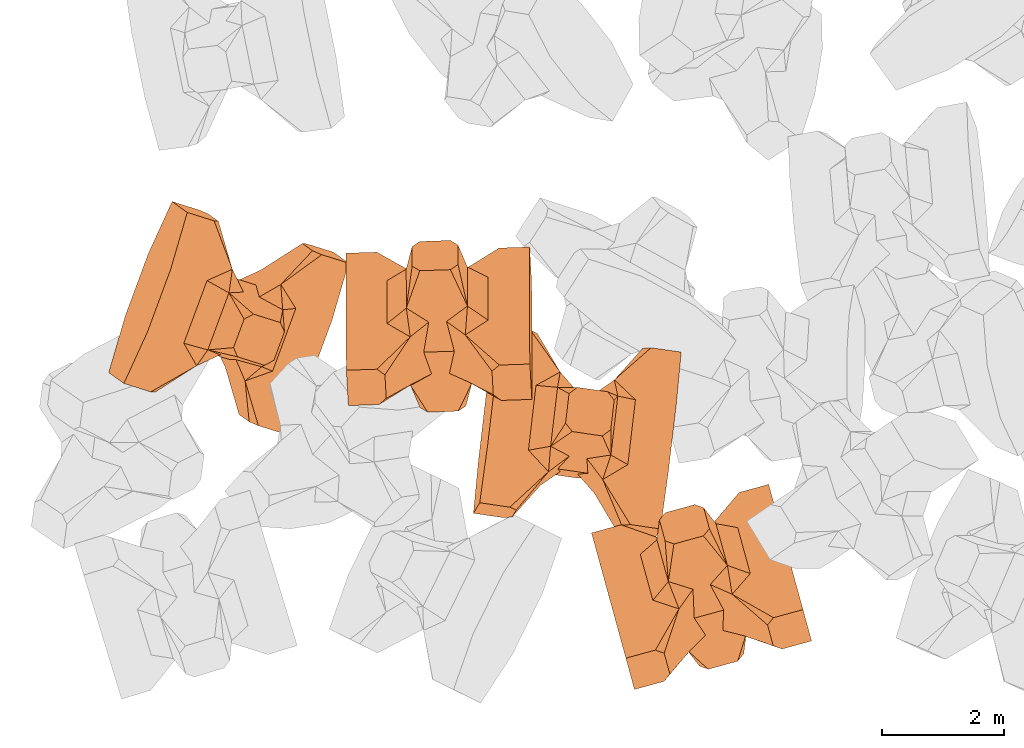
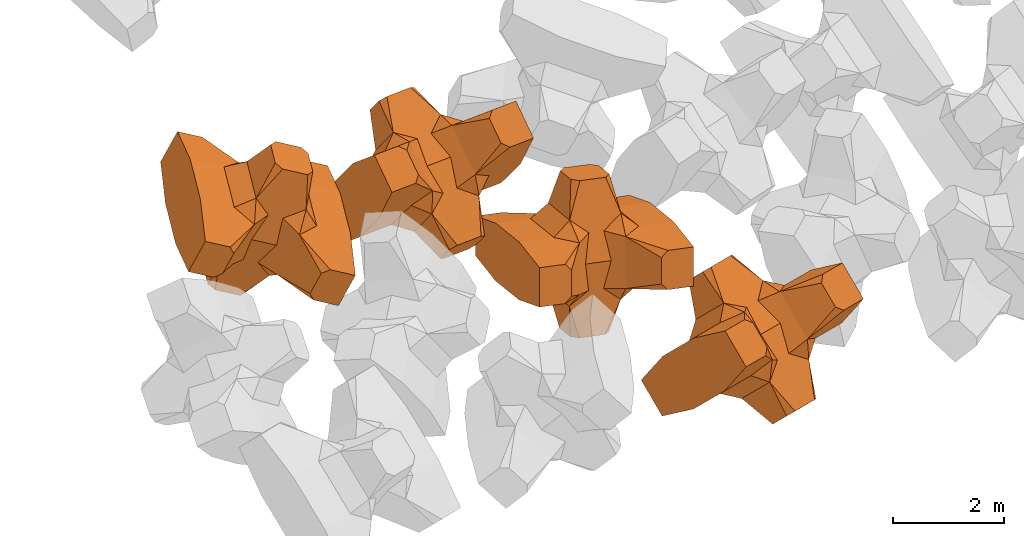
# One storey, part 2 of 17: 4 civil elements.
"""IFC4 building model written with IfcOpenShell, lengths in metres."""

from ifc_helpers import new_model, entity, si_unit, converted_unit, frame, origin_with_axes, origin_2d_with_axis, place, context, subcontext, project, spatial, polygons, element, save


model = new_model("IFC4")

# Units and contexts
model_context = context("Model", 3, precision=1e-05, world=origin_with_axes())
plan_context = context("Plan", 2, precision=1e-05, world=origin_2d_with_axis())
body_context = subcontext(model_context, "Body", "Model", "MODEL_VIEW")
ifc_project = project(units=[si_unit("VOLUMEUNIT", "CUBIC_METRE"), si_unit("LENGTHUNIT", "METRE"), converted_unit("PLANEANGLEUNIT", "degree", entity("IfcReal", 0.0174532925199433), si_unit("PLANEANGLEUNIT", "RADIAN"), dimensions=[0, 0, 0, 0, 0, 0, 0]), si_unit("AREAUNIT", "SQUARE_METRE")], contexts=[model_context, plan_context])

# Site, building, storey
site_placement = place(None, origin_with_axes())
site = spatial("IfcSite", under=ifc_project, at=site_placement)
building_placement = place(site_placement, origin_with_axes())
building = spatial("IfcBuilding", under=site, at=building_placement, Name="Building")
storey_placement = place(building_placement, origin_with_axes())
storey = spatial("IfcBuildingStorey", under=building, at=storey_placement, Name="Storey")

# Civil elements
civil_element_1_placement = place(storey_placement, frame((10.1557922363281, -20.4937763214111, 2.37215161323547), z_axis=(0.186987502851057, -0.681988531796913, -0.707055384163799), x_axis=(-0.18698757723591, 0.681881898647202, -0.707158201717785)))
element("IfcCivilElement", 1, at=civil_element_1_placement, inside=storey, ObjectType="IfcCivilElementType", context=body_context, shape_type="Tessellation", body=[
    polygons([(0.500000059604645, 0.499999970197678, 0.821428656578064), (0.374999791383743, 0.249999895691872, 1.5), (0.549999952316284, 0.145680591464043, 0.550000071525574), (0.374999791383743, -0.249999970197678, 1.5), (0.651315748691559, -0.249999970197678, 1.45970545872842e-07), (0.651315748691559, 0.249999895691872, 1.45970545872842e-07), (0.549999952316284, -0.145680665969849, 0.550000071525574), (0.500000059604645, -0.499999970197678, 0.821428656578064), (-0.249999970197678, 0.374999731779099, 1.5), (0.249999940395355, 0.374999731779099, 1.5), (-0.5, 0.499999970197678, 0.821428656578064), (-0.549999952316284, 0.824999809265137, 0.550000071525574), (0.549999952316284, 0.824999809265137, 0.550000071525574), (-0.549999952316284, 1.49999976158142, 0.550000071525574), (0.549999952316284, 1.49999976158142, 0.550000071525574), (-0.249999970197678, -0.374999940395355, 1.5), (0.249999940395355, -0.374999940395355, 1.5), (-0.374999940395355, -0.249999970197678, 1.5), (-0.374999940395355, 0.249999895691872, 1.5), (1.49999988079071, 0.874999701976776, -0.249999806284904), (1.49999988079071, 0.874999701976776, 0.25000011920929), (0.845557451248169, 0.449999809265137, -0.495555102825165), (0.845557451248169, 0.449999809265137, 0.495555102825165), (1.49999988079071, 1.49999976158142, -0.374999791383743), (1.49999988079071, 1.49999976158142, 0.374999940395355), (1.49999988079071, 0.999999821186066, -0.374999791383743), (1.49999988079071, 0.999999821186066, 0.374999940395355), (-1.49999988079071, 1.49999976158142, -0.374999791383743), (-1.49999988079071, 1.49999976158142, 0.374999940395355), (-0.549999952316284, 1.49999976158142, -0.54999977350235), (0.549999952316284, 1.49999976158142, -0.54999977350235), (0.549999952316284, 0.145680591464043, -0.54999977350235), (-0.5, -0.499999970197678, 0.821428656578064), (-0.549999952316284, -0.145680665969849, 0.550000071525574), (-0.651315748691559, 0.249999895691872, 1.45970545872842e-07), (-0.651315748691559, -0.249999970197678, 1.45970545872842e-07), (-0.549999952316284, 0.145680591464043, 0.550000071525574), (-1.49999988079071, 0.874999701976776, 0.25000011920929), (-1.49999988079071, 0.874999701976776, -0.249999806284904), (-0.845557332038879, 0.449999809265137, 0.495555102825165), (-0.845557332038879, 0.449999809265137, -0.495555102825165), (-1.49999988079071, 0.999999821186066, 0.374999940395355), (-1.49999988079071, 0.999999821186066, -0.374999791383743), (-0.549999952316284, 0.145680591464043, -0.54999977350235), (0.549999952316284, -0.824999988079071, 0.550000071525574), (-0.549999952316284, -0.824999988079071, 0.550000071525574), (0.549999952316284, -1.49999976158142, 0.550000071525574), (-0.549999952316284, -1.49999976158142, 0.550000071525574), (1.49999988079071, -0.874999940395355, 0.25000011920929), (1.49999988079071, -0.874999940395355, -0.249999806284904), (0.845557451248169, -0.450000047683716, 0.495555102825165), (0.845557451248169, -0.450000047683716, -0.495555102825165), (1.49999988079071, -1.49999976158142, 0.374999940395355), (1.49999988079071, -1.49999976158142, -0.374999791383743), (1.49999988079071, -0.999999940395355, 0.374999940395355), (1.49999988079071, -0.999999940395355, -0.374999791383743), (0.549999952316284, -1.49999976158142, -0.54999977350235), (-0.549999952316284, -1.49999976158142, -0.54999977350235), (-1.49999988079071, -1.49999976158142, -0.374999791383743), (-1.49999988079071, -1.49999976158142, 0.374999940395355), (0.549999952316284, -0.145680665969849, -0.54999977350235), (-1.49999988079071, -0.874999940395355, -0.249999806284904), (-1.49999988079071, -0.874999940395355, 0.25000011920929), (-0.845557332038879, -0.450000047683716, -0.495555102825165), (-0.845557332038879, -0.450000047683716, 0.495555102825165), (-1.49999988079071, -0.999999940395355, -0.374999791383743), (-1.49999988079071, -0.999999940395355, 0.374999940395355), (-0.549999952316284, -0.145680665969849, -0.54999977350235), (0.500000059604645, -0.499999970197678, -0.821428418159485), (0.374999791383743, -0.249999970197678, -1.49999976158142), (0.374999791383743, 0.249999895691872, -1.49999976158142), (0.500000059604645, 0.499999970197678, -0.821428418159485), (0.249999940395355, 0.374999731779099, -1.49999976158142), (-0.249999970197678, 0.374999731779099, -1.49999976158142), (-0.5, 0.499999970197678, -0.821428418159485), (0.549999952316284, 0.824999809265137, -0.54999977350235), (-0.549999952316284, 0.824999809265137, -0.54999977350235), (0.249999940395355, -0.374999940395355, -1.49999976158142), (-0.249999970197678, -0.374999940395355, -1.49999976158142), (-0.374999940395355, -0.249999970197678, -1.49999976158142), (-0.374999940395355, 0.249999895691872, -1.49999976158142), (-0.5, -0.499999970197678, -0.821428418159485), (-0.549999952316284, -0.824999988079071, -0.54999977350235), (0.549999952316284, -0.824999988079071, -0.54999977350235)], [[[1, 2, 3]], [[3, 2, 4]], [[5, 6, 7]], [[7, 6, 3]], [[7, 3, 8]], [[8, 3, 4]], [[9, 10, 11]], [[11, 10, 1]], [[12, 13, 14]], [[14, 13, 15]], [[16, 17, 18]], [[18, 17, 4]], [[18, 4, 19]], [[19, 4, 2]], [[19, 2, 9]], [[9, 2, 10]], [[20, 21, 22]], [[22, 21, 23]], [[24, 25, 26]], [[26, 25, 27]], [[26, 27, 20]], [[20, 27, 21]], [[23, 27, 13]], [[13, 27, 25]], [[13, 25, 15]], [[28, 29, 30]], [[30, 29, 14]], [[30, 14, 31]], [[31, 14, 15]], [[31, 15, 24]], [[24, 15, 25]], [[21, 27, 23]], [[2, 1, 10]], [[13, 12, 1]], [[1, 12, 11]], [[13, 1, 23]], [[32, 22, 6]], [[6, 22, 23]], [[6, 23, 3]], [[3, 23, 1]], [[33, 18, 34]], [[34, 18, 19]], [[35, 36, 37]], [[37, 36, 34]], [[37, 34, 11]], [[11, 34, 19]], [[38, 39, 40]], [[40, 39, 41]], [[29, 28, 42]], [[42, 28, 43]], [[42, 43, 38]], [[38, 43, 39]], [[14, 29, 12]], [[12, 29, 42]], [[12, 42, 40]], [[40, 42, 38]], [[9, 11, 19]], [[40, 11, 12]], [[37, 40, 35]], [[35, 40, 41]], [[35, 41, 44]], [[11, 40, 37]], [[17, 16, 8]], [[8, 16, 33]], [[45, 46, 47]], [[47, 46, 48]], [[49, 50, 51]], [[51, 50, 52]], [[53, 54, 55]], [[55, 54, 56]], [[55, 56, 49]], [[49, 56, 50]], [[47, 53, 45]], [[45, 53, 55]], [[45, 55, 51]], [[54, 53, 57]], [[57, 53, 47]], [[57, 47, 58]], [[58, 47, 48]], [[58, 48, 59]], [[59, 48, 60]], [[51, 55, 49]], [[17, 8, 4]], [[46, 45, 33]], [[33, 45, 8]], [[51, 8, 45]], [[7, 51, 5]], [[5, 51, 52]], [[5, 52, 61]], [[8, 51, 7]], [[62, 63, 64]], [[64, 63, 65]], [[59, 60, 66]], [[66, 60, 67]], [[66, 67, 62]], [[62, 67, 63]], [[65, 67, 46]], [[46, 67, 60]], [[46, 60, 48]], [[63, 67, 65]], [[18, 33, 16]], [[46, 33, 65]], [[68, 64, 36]], [[36, 64, 65]], [[36, 65, 34]], [[34, 65, 33]], [[69, 70, 61]], [[61, 70, 71]], [[6, 5, 32]], [[32, 5, 61]], [[32, 61, 72]], [[72, 61, 71]], [[73, 74, 72]], [[72, 74, 75]], [[76, 77, 31]], [[31, 77, 30]], [[78, 79, 70]], [[70, 79, 80]], [[70, 80, 71]], [[71, 80, 81]], [[71, 81, 73]], [[73, 81, 74]], [[31, 24, 76]], [[76, 24, 26]], [[76, 26, 22]], [[22, 26, 20]], [[73, 72, 71]], [[77, 76, 75]], [[75, 76, 72]], [[22, 72, 76]], [[72, 22, 32]], [[75, 81, 44]], [[44, 81, 80]], [[36, 35, 68]], [[68, 35, 44]], [[68, 44, 82]], [[82, 44, 80]], [[41, 43, 77]], [[77, 43, 28]], [[77, 28, 30]], [[39, 43, 41]], [[81, 75, 74]], [[77, 75, 41]], [[44, 41, 75]], [[79, 78, 82]], [[82, 78, 69]], [[83, 84, 58]], [[58, 84, 57]], [[52, 56, 84]], [[84, 56, 54]], [[84, 54, 57]], [[50, 56, 52]], [[70, 69, 78]], [[84, 83, 69]], [[69, 83, 82]], [[84, 69, 52]], [[61, 52, 69]], [[58, 59, 83]], [[83, 59, 66]], [[83, 66, 64]], [[64, 66, 62]], [[79, 82, 80]], [[64, 82, 83]], [[82, 64, 68]]], closed=True),
])
civil_element_2_placement = place(storey_placement, frame((8.1265926361084, -17.9750919342041, 3.49321746826172), z_axis=(-0.136906563876709, -0.229293614024707, -0.963680980062884), x_axis=(0.11298064851695, 0.962878581808255, -0.245153441247749)))
element("IfcCivilElement", 2, at=civil_element_2_placement, inside=storey, ObjectType="IfcCivilElementType", context=body_context, shape_type="Tessellation", body=[
    polygons([(0.500000178813934, 0.500000059604645, 0.821428835391998), (0.374999850988388, 0.249999940395355, 1.50000035762787), (0.550000071525574, 0.145680621266365, 0.550000190734863), (0.374999850988388, -0.250000029802322, 1.50000035762787), (0.651315867900848, -0.250000029802322, 1.45970574294552e-07), (0.651315867900848, 0.249999940395355, 1.45970574294552e-07), (0.550000071525574, -0.145680695772171, 0.550000190734863), (0.500000178813934, -0.500000059604645, 0.821428835391998), (-0.250000029802322, 0.374999791383743, 1.50000035762787), (0.249999985098839, 0.374999791383743, 1.50000035762787), (-0.500000059604645, 0.500000059604645, 0.821428835391998), (-0.550000071525574, 0.824999988079071, 0.550000190734863), (0.550000071525574, 0.824999988079071, 0.550000190734863), (-0.550000071525574, 1.5, 0.550000190734863), (0.550000071525574, 1.5, 0.550000190734863), (-0.250000029802322, -0.375, 1.50000035762787), (0.249999985098839, -0.375, 1.50000035762787), (-0.375, -0.250000029802322, 1.50000035762787), (-0.375, 0.249999940395355, 1.50000035762787), (1.50000023841858, 0.87499988079071, -0.249999865889549), (1.50000023841858, 0.87499988079071, 0.250000149011612), (0.845557630062103, 0.449999898672104, -0.495555222034454), (0.845557630062103, 0.449999898672104, 0.495555222034454), (1.50000023841858, 1.5, -0.374999850988388), (1.50000023841858, 1.5, 0.375), (1.50000023841858, 1.0, -0.374999850988388), (1.50000023841858, 1.0, 0.375), (-1.50000023841858, 1.5, -0.374999850988388), (-1.50000023841858, 1.5, 0.375), (-0.550000071525574, 1.5, -0.549999892711639), (0.550000071525574, 1.5, -0.549999892711639), (0.550000071525574, 0.145680621266365, -0.549999892711639), (-0.500000059604645, -0.500000059604645, 0.821428835391998), (-0.550000071525574, -0.145680695772171, 0.550000190734863), (-0.651315867900848, 0.249999940395355, 1.45970574294552e-07), (-0.651315867900848, -0.250000029802322, 1.45970574294552e-07), (-0.550000071525574, 0.145680621266365, 0.550000190734863), (-1.50000023841858, 0.87499988079071, 0.250000149011612), (-1.50000023841858, 0.87499988079071, -0.249999865889549), (-0.845557451248169, 0.449999898672104, 0.495555222034454), (-0.845557451248169, 0.449999898672104, -0.495555222034454), (-1.50000023841858, 1.0, 0.375), (-1.50000023841858, 1.0, -0.374999850988388), (-0.550000071525574, 0.145680621266365, -0.549999892711639), (0.550000071525574, -0.825000107288361, 0.550000190734863), (-0.550000071525574, -0.825000107288361, 0.550000190734863), (0.550000071525574, -1.5, 0.550000190734863), (-0.550000071525574, -1.5, 0.550000190734863), (1.50000023841858, -0.875000059604645, 0.250000149011612), (1.50000023841858, -0.875000059604645, -0.249999865889549), (0.845557630062103, -0.450000137090683, 0.495555222034454), (0.845557630062103, -0.450000137090683, -0.495555222034454), (1.50000023841858, -1.5, 0.375), (1.50000023841858, -1.5, -0.374999850988388), (1.50000023841858, -1.00000011920929, 0.375), (1.50000023841858, -1.00000011920929, -0.374999850988388), (0.550000071525574, -1.5, -0.549999892711639), (-0.550000071525574, -1.5, -0.549999892711639), (-1.50000023841858, -1.5, -0.374999850988388), (-1.50000023841858, -1.5, 0.375), (0.550000071525574, -0.145680695772171, -0.549999892711639), (-1.50000023841858, -0.875000059604645, -0.249999865889549), (-1.50000023841858, -0.875000059604645, 0.250000149011612), (-0.845557451248169, -0.450000137090683, -0.495555222034454), (-0.845557451248169, -0.450000137090683, 0.495555222034454), (-1.50000023841858, -1.00000011920929, -0.374999850988388), (-1.50000023841858, -1.00000011920929, 0.375), (-0.550000071525574, -0.145680695772171, -0.549999892711639), (0.500000178813934, -0.500000059604645, -0.821428596973419), (0.374999850988388, -0.250000029802322, -1.5), (0.374999850988388, 0.249999940395355, -1.5), (0.500000178813934, 0.500000059604645, -0.821428596973419), (0.249999985098839, 0.374999791383743, -1.5), (-0.250000029802322, 0.374999791383743, -1.5), (-0.500000059604645, 0.500000059604645, -0.821428596973419), (0.550000071525574, 0.824999988079071, -0.549999892711639), (-0.550000071525574, 0.824999988079071, -0.549999892711639), (0.249999985098839, -0.375, -1.5), (-0.250000029802322, -0.375, -1.5), (-0.375, -0.250000029802322, -1.5), (-0.375, 0.249999940395355, -1.5), (-0.500000059604645, -0.500000059604645, -0.821428596973419), (-0.550000071525574, -0.825000107288361, -0.549999892711639), (0.550000071525574, -0.825000107288361, -0.549999892711639)], [[[1, 2, 3]], [[3, 2, 4]], [[5, 6, 7]], [[7, 6, 3]], [[7, 3, 8]], [[8, 3, 4]], [[9, 10, 11]], [[11, 10, 1]], [[12, 13, 14]], [[14, 13, 15]], [[16, 17, 18]], [[18, 17, 4]], [[18, 4, 19]], [[19, 4, 2]], [[19, 2, 9]], [[9, 2, 10]], [[20, 21, 22]], [[22, 21, 23]], [[24, 25, 26]], [[26, 25, 27]], [[26, 27, 20]], [[20, 27, 21]], [[23, 27, 13]], [[13, 27, 25]], [[13, 25, 15]], [[28, 29, 30]], [[30, 29, 14]], [[30, 14, 31]], [[31, 14, 15]], [[31, 15, 24]], [[24, 15, 25]], [[21, 27, 23]], [[2, 1, 10]], [[13, 12, 1]], [[1, 12, 11]], [[13, 1, 23]], [[32, 22, 6]], [[6, 22, 23]], [[6, 23, 3]], [[3, 23, 1]], [[33, 18, 34]], [[34, 18, 19]], [[35, 36, 37]], [[37, 36, 34]], [[37, 34, 11]], [[11, 34, 19]], [[38, 39, 40]], [[40, 39, 41]], [[29, 28, 42]], [[42, 28, 43]], [[42, 43, 38]], [[38, 43, 39]], [[14, 29, 12]], [[12, 29, 42]], [[12, 42, 40]], [[40, 42, 38]], [[9, 11, 19]], [[40, 11, 12]], [[37, 40, 35]], [[35, 40, 41]], [[35, 41, 44]], [[11, 40, 37]], [[17, 16, 8]], [[8, 16, 33]], [[45, 46, 47]], [[47, 46, 48]], [[49, 50, 51]], [[51, 50, 52]], [[53, 54, 55]], [[55, 54, 56]], [[55, 56, 49]], [[49, 56, 50]], [[47, 53, 45]], [[45, 53, 55]], [[45, 55, 51]], [[54, 53, 57]], [[57, 53, 47]], [[57, 47, 58]], [[58, 47, 48]], [[58, 48, 59]], [[59, 48, 60]], [[51, 55, 49]], [[17, 8, 4]], [[46, 45, 33]], [[33, 45, 8]], [[51, 8, 45]], [[7, 51, 5]], [[5, 51, 52]], [[5, 52, 61]], [[8, 51, 7]], [[62, 63, 64]], [[64, 63, 65]], [[59, 60, 66]], [[66, 60, 67]], [[66, 67, 62]], [[62, 67, 63]], [[65, 67, 46]], [[46, 67, 60]], [[46, 60, 48]], [[63, 67, 65]], [[18, 33, 16]], [[46, 33, 65]], [[68, 64, 36]], [[36, 64, 65]], [[36, 65, 34]], [[34, 65, 33]], [[69, 70, 61]], [[61, 70, 71]], [[6, 5, 32]], [[32, 5, 61]], [[32, 61, 72]], [[72, 61, 71]], [[73, 74, 72]], [[72, 74, 75]], [[76, 77, 31]], [[31, 77, 30]], [[78, 79, 70]], [[70, 79, 80]], [[70, 80, 71]], [[71, 80, 81]], [[71, 81, 73]], [[73, 81, 74]], [[31, 24, 76]], [[76, 24, 26]], [[76, 26, 22]], [[22, 26, 20]], [[73, 72, 71]], [[77, 76, 75]], [[75, 76, 72]], [[22, 72, 76]], [[72, 22, 32]], [[75, 81, 44]], [[44, 81, 80]], [[36, 35, 68]], [[68, 35, 44]], [[68, 44, 82]], [[82, 44, 80]], [[41, 43, 77]], [[77, 43, 28]], [[77, 28, 30]], [[39, 43, 41]], [[81, 75, 74]], [[77, 75, 41]], [[44, 41, 75]], [[79, 78, 82]], [[82, 78, 69]], [[83, 84, 58]], [[58, 84, 57]], [[52, 56, 84]], [[84, 56, 54]], [[84, 54, 57]], [[50, 56, 52]], [[70, 69, 78]], [[84, 83, 69]], [[69, 83, 82]], [[84, 69, 52]], [[61, 52, 69]], [[58, 59, 83]], [[83, 59, 66]], [[83, 66, 64]], [[64, 66, 62]], [[79, 82, 80]], [[64, 82, 83]], [[82, 64, 68]]], closed=True),
])
civil_element_3_placement = place(storey_placement, frame((5.86764192581177, -16.2369613647461, 4.94633722305298), z_axis=(-0.0428975516343517, 0.769931841735194, 0.636682620420904), x_axis=(0.00109299982129817, -0.637232659483879, 0.770670709861542)))
element("IfcCivilElement", 3, at=civil_element_3_placement, inside=storey, ObjectType="IfcCivilElementType", context=body_context, shape_type="Tessellation", body=[
    polygons([(0.50000011920929, 0.500001847743988, 0.821428716182709), (0.374999821186066, 0.250000834465027, 1.50000023841858), (0.550000011920929, 0.145681157708168, 0.550000131130219), (0.374999821186066, -0.250000923871994, 1.50000023841858), (0.651315808296204, -0.250000923871994, 1.45970560083697e-07), (0.651315808296204, 0.250000834465027, 1.45970560083697e-07), (0.550000011920929, -0.145681217312813, 0.550000131130219), (0.50000011920929, -0.500001847743988, 0.821428716182709), (-0.25, 0.375001132488251, 1.50000023841858), (0.249999970197678, 0.375001132488251, 1.50000023841858), (-0.500000059604645, 0.500001847743988, 0.821428716182709), (-0.550000011920929, 0.82500296831131, 0.550000131130219), (0.550000011920929, 0.82500296831131, 0.550000131130219), (-0.550000011920929, 1.50000548362732, 0.550000131130219), (0.550000011920929, 1.50000548362732, 0.550000131130219), (-0.25, -0.37500137090683, 1.50000023841858), (0.249999970197678, -0.37500137090683, 1.50000023841858), (-0.374999970197678, -0.250000923871994, 1.50000023841858), (-0.374999970197678, 0.250000834465027, 1.50000023841858), (1.5, 0.875003039836884, -0.249999836087227), (1.5, 0.875003039836884, 0.25000011920929), (0.845557510852814, 0.450001537799835, -0.49555516242981), (0.845557510852814, 0.450001537799835, 0.49555516242981), (1.5, 1.50000548362732, -0.374999821186066), (1.5, 1.50000548362732, 0.374999970197678), (1.5, 1.00000357627869, -0.374999821186066), (1.5, 1.00000357627869, 0.374999970197678), (-1.5, 1.50000548362732, -0.374999821186066), (-1.5, 1.50000548362732, 0.374999970197678), (-0.550000011920929, 1.50000548362732, -0.549999833106995), (0.550000011920929, 1.50000548362732, -0.549999833106995), (0.550000011920929, 0.145681157708168, -0.549999833106995), (-0.500000059604645, -0.500001847743988, 0.821428716182709), (-0.550000011920929, -0.145681217312813, 0.550000131130219), (-0.651315808296204, 0.250000834465027, 1.45970560083697e-07), (-0.651315808296204, -0.250000923871994, 1.45970560083697e-07), (-0.550000011920929, 0.145681157708168, 0.550000131130219), (-1.5, 0.875003039836884, 0.25000011920929), (-1.5, 0.875003039836884, -0.249999836087227), (-0.845557391643524, 0.450001537799835, 0.49555516242981), (-0.845557391643524, 0.450001537799835, -0.49555516242981), (-1.5, 1.00000357627869, 0.374999970197678), (-1.5, 1.00000357627869, -0.374999821186066), (-0.550000011920929, 0.145681157708168, -0.549999833106995), (0.550000011920929, -0.825003087520599, 0.550000131130219), (-0.550000011920929, -0.825003087520599, 0.550000131130219), (0.550000011920929, -1.50000548362732, 0.550000131130219), (-0.550000011920929, -1.50000548362732, 0.550000131130219), (1.5, -0.875003218650818, 0.25000011920929), (1.5, -0.875003218650818, -0.249999836087227), (0.845557510852814, -0.450001746416092, 0.49555516242981), (0.845557510852814, -0.450001746416092, -0.49555516242981), (1.5, -1.50000548362732, 0.374999970197678), (1.5, -1.50000548362732, -0.374999821186066), (1.5, -1.00000369548798, 0.374999970197678), (1.5, -1.00000369548798, -0.374999821186066), (0.550000011920929, -1.50000548362732, -0.549999833106995), (-0.550000011920929, -1.50000548362732, -0.549999833106995), (-1.5, -1.50000548362732, -0.374999821186066), (-1.5, -1.50000548362732, 0.374999970197678), (0.550000011920929, -0.145681217312813, -0.549999833106995), (-1.5, -0.875003218650818, -0.249999836087227), (-1.5, -0.875003218650818, 0.25000011920929), (-0.845557391643524, -0.450001746416092, -0.49555516242981), (-0.845557391643524, -0.450001746416092, 0.49555516242981), (-1.5, -1.00000369548798, -0.374999821186066), (-1.5, -1.00000369548798, 0.374999970197678), (-0.550000011920929, -0.145681217312813, -0.549999833106995), (0.50000011920929, -0.500001847743988, -0.821428537368774), (0.374999821186066, -0.250000923871994, -1.49999988079071), (0.374999821186066, 0.250000834465027, -1.49999988079071), (0.50000011920929, 0.500001847743988, -0.821428537368774), (0.249999970197678, 0.375001132488251, -1.49999988079071), (-0.25, 0.375001132488251, -1.49999988079071), (-0.500000059604645, 0.500001847743988, -0.821428537368774), (0.550000011920929, 0.82500296831131, -0.549999833106995), (-0.550000011920929, 0.82500296831131, -0.549999833106995), (0.249999970197678, -0.37500137090683, -1.49999988079071), (-0.25, -0.37500137090683, -1.49999988079071), (-0.374999970197678, -0.250000923871994, -1.49999988079071), (-0.374999970197678, 0.250000834465027, -1.49999988079071), (-0.500000059604645, -0.500001847743988, -0.821428537368774), (-0.550000011920929, -0.825003087520599, -0.549999833106995), (0.550000011920929, -0.825003087520599, -0.549999833106995)], [[[1, 2, 3]], [[3, 2, 4]], [[5, 6, 7]], [[7, 6, 3]], [[7, 3, 8]], [[8, 3, 4]], [[9, 10, 11]], [[11, 10, 1]], [[12, 13, 14]], [[14, 13, 15]], [[16, 17, 18]], [[18, 17, 4]], [[18, 4, 19]], [[19, 4, 2]], [[19, 2, 9]], [[9, 2, 10]], [[20, 21, 22]], [[22, 21, 23]], [[24, 25, 26]], [[26, 25, 27]], [[26, 27, 20]], [[20, 27, 21]], [[23, 27, 13]], [[13, 27, 25]], [[13, 25, 15]], [[28, 29, 30]], [[30, 29, 14]], [[30, 14, 31]], [[31, 14, 15]], [[31, 15, 24]], [[24, 15, 25]], [[21, 27, 23]], [[2, 1, 10]], [[13, 12, 1]], [[1, 12, 11]], [[13, 1, 23]], [[32, 22, 6]], [[6, 22, 23]], [[6, 23, 3]], [[3, 23, 1]], [[33, 18, 34]], [[34, 18, 19]], [[35, 36, 37]], [[37, 36, 34]], [[37, 34, 11]], [[11, 34, 19]], [[38, 39, 40]], [[40, 39, 41]], [[29, 28, 42]], [[42, 28, 43]], [[42, 43, 38]], [[38, 43, 39]], [[14, 29, 12]], [[12, 29, 42]], [[12, 42, 40]], [[40, 42, 38]], [[9, 11, 19]], [[40, 11, 12]], [[37, 40, 35]], [[35, 40, 41]], [[35, 41, 44]], [[11, 40, 37]], [[17, 16, 8]], [[8, 16, 33]], [[45, 46, 47]], [[47, 46, 48]], [[49, 50, 51]], [[51, 50, 52]], [[53, 54, 55]], [[55, 54, 56]], [[55, 56, 49]], [[49, 56, 50]], [[47, 53, 45]], [[45, 53, 55]], [[45, 55, 51]], [[54, 53, 57]], [[57, 53, 47]], [[57, 47, 58]], [[58, 47, 48]], [[58, 48, 59]], [[59, 48, 60]], [[51, 55, 49]], [[17, 8, 4]], [[46, 45, 33]], [[33, 45, 8]], [[51, 8, 45]], [[7, 51, 5]], [[5, 51, 52]], [[5, 52, 61]], [[8, 51, 7]], [[62, 63, 64]], [[64, 63, 65]], [[59, 60, 66]], [[66, 60, 67]], [[66, 67, 62]], [[62, 67, 63]], [[65, 67, 46]], [[46, 67, 60]], [[46, 60, 48]], [[63, 67, 65]], [[18, 33, 16]], [[46, 33, 65]], [[68, 64, 36]], [[36, 64, 65]], [[36, 65, 34]], [[34, 65, 33]], [[69, 70, 61]], [[61, 70, 71]], [[6, 5, 32]], [[32, 5, 61]], [[32, 61, 72]], [[72, 61, 71]], [[73, 74, 72]], [[72, 74, 75]], [[76, 77, 31]], [[31, 77, 30]], [[78, 79, 70]], [[70, 79, 80]], [[70, 80, 71]], [[71, 80, 81]], [[71, 81, 73]], [[73, 81, 74]], [[31, 24, 76]], [[76, 24, 26]], [[76, 26, 22]], [[22, 26, 20]], [[73, 72, 71]], [[77, 76, 75]], [[75, 76, 72]], [[22, 72, 76]], [[72, 22, 32]], [[75, 81, 44]], [[44, 81, 80]], [[36, 35, 68]], [[68, 35, 44]], [[68, 44, 82]], [[82, 44, 80]], [[41, 43, 77]], [[77, 43, 28]], [[77, 28, 30]], [[39, 43, 41]], [[81, 75, 74]], [[77, 75, 41]], [[44, 41, 75]], [[79, 78, 82]], [[82, 78, 69]], [[83, 84, 58]], [[58, 84, 57]], [[52, 56, 84]], [[84, 56, 54]], [[84, 54, 57]], [[50, 56, 52]], [[70, 69, 78]], [[84, 83, 69]], [[69, 83, 82]], [[84, 69, 52]], [[61, 52, 69]], [[58, 59, 83]], [[83, 59, 66]], [[83, 66, 64]], [[64, 66, 62]], [[79, 82, 80]], [[64, 82, 83]], [[82, 64, 68]]], closed=True),
])
civil_element_4_placement = place(storey_placement, frame((2.43280649185181, -16.0993576049805, 5.06278371810913), z_axis=(0.329851054496151, -0.23805297434155, 0.913525622659221), x_axis=(-0.344859723991096, -0.93119044384856, -0.118136057382605)))
element("IfcCivilElement", 4, at=civil_element_4_placement, inside=storey, ObjectType="IfcCivilElementType", context=body_context, shape_type="Tessellation", body=[
    polygons([(0.500000178813934, 0.50000011920929, 0.821429014205933), (0.374999850988388, 0.249999970197678, 1.50000059604645), (0.550000071525574, 0.145680636167526, 0.550000309944153), (0.374999850988388, -0.250000029802322, 1.50000059604645), (0.651315867900848, -0.250000029802322, 1.45970602716261e-07), (0.651315867900848, 0.249999970197678, 1.45970602716261e-07), (0.550000071525574, -0.145680710673332, 0.550000309944153), (0.500000178813934, -0.50000011920929, 0.821429014205933), (-0.250000029802322, 0.374999821186066, 1.50000059604645), (0.249999985098839, 0.374999821186066, 1.50000059604645), (-0.500000059604645, 0.50000011920929, 0.821429014205933), (-0.550000071525574, 0.825000047683716, 0.550000309944153), (0.550000071525574, 0.825000047683716, 0.550000309944153), (-0.550000071525574, 1.50000023841858, 0.550000309944153), (0.550000071525574, 1.50000023841858, 0.550000309944153), (-0.250000029802322, -0.375000059604645, 1.50000059604645), (0.249999985098839, -0.375000059604645, 1.50000059604645), (-0.375, -0.250000029802322, 1.50000059604645), (-0.375, 0.249999970197678, 1.50000059604645), (1.50000023841858, 0.874999940395355, -0.249999910593033), (1.50000023841858, 0.874999940395355, 0.250000208616257), (0.845557630062103, 0.449999958276749, -0.495555311441422), (0.845557630062103, 0.449999958276749, 0.495555311441422), (1.50000023841858, 1.50000023841858, -0.374999940395355), (1.50000023841858, 1.50000023841858, 0.375000089406967), (1.50000023841858, 1.00000011920929, -0.374999940395355), (1.50000023841858, 1.00000011920929, 0.375000089406967), (-1.50000023841858, 1.50000023841858, -0.374999940395355), (-1.50000023841858, 1.50000023841858, 0.375000089406967), (-0.550000071525574, 1.50000023841858, -0.550000011920929), (0.550000071525574, 1.50000023841858, -0.550000011920929), (0.550000071525574, 0.145680636167526, -0.550000011920929), (-0.500000059604645, -0.50000011920929, 0.821429014205933), (-0.550000071525574, -0.145680710673332, 0.550000309944153), (-0.651315867900848, 0.249999970197678, 1.45970602716261e-07), (-0.651315867900848, -0.250000029802322, 1.45970602716261e-07), (-0.550000071525574, 0.145680636167526, 0.550000309944153), (-1.50000023841858, 0.874999940395355, 0.250000208616257), (-1.50000023841858, 0.874999940395355, -0.249999910593033), (-0.845557451248169, 0.449999958276749, 0.495555311441422), (-0.845557451248169, 0.449999958276749, -0.495555311441422), (-1.50000023841858, 1.00000011920929, 0.375000089406967), (-1.50000023841858, 1.00000011920929, -0.374999940395355), (-0.550000071525574, 0.145680636167526, -0.550000011920929), (0.550000071525574, -0.82500022649765, 0.550000309944153), (-0.550000071525574, -0.82500022649765, 0.550000309944153), (0.550000071525574, -1.50000023841858, 0.550000309944153), (-0.550000071525574, -1.50000023841858, 0.550000309944153), (1.50000023841858, -0.875000178813934, 0.250000208616257), (1.50000023841858, -0.875000178813934, -0.249999910593033), (0.845557630062103, -0.450000166893005, 0.495555311441422), (0.845557630062103, -0.450000166893005, -0.495555311441422), (1.50000023841858, -1.50000023841858, 0.375000089406967), (1.50000023841858, -1.50000023841858, -0.374999940395355), (1.50000023841858, -1.00000023841858, 0.375000089406967), (1.50000023841858, -1.00000023841858, -0.374999940395355), (0.550000071525574, -1.50000023841858, -0.550000011920929), (-0.550000071525574, -1.50000023841858, -0.550000011920929), (-1.50000023841858, -1.50000023841858, -0.374999940395355), (-1.50000023841858, -1.50000023841858, 0.375000089406967), (0.550000071525574, -0.145680710673332, -0.550000011920929), (-1.50000023841858, -0.875000178813934, -0.249999910593033), (-1.50000023841858, -0.875000178813934, 0.250000208616257), (-0.845557451248169, -0.450000166893005, -0.495555311441422), (-0.845557451248169, -0.450000166893005, 0.495555311441422), (-1.50000023841858, -1.00000023841858, -0.374999940395355), (-1.50000023841858, -1.00000023841858, 0.375000089406967), (-0.550000071525574, -0.145680710673332, -0.550000011920929), (0.500000178813934, -0.50000011920929, -0.821428775787354), (0.374999850988388, -0.250000029802322, -1.50000035762787), (0.374999850988388, 0.249999970197678, -1.50000035762787), (0.500000178813934, 0.50000011920929, -0.821428775787354), (0.249999985098839, 0.374999821186066, -1.50000035762787), (-0.250000029802322, 0.374999821186066, -1.50000035762787), (-0.500000059604645, 0.50000011920929, -0.821428775787354), (0.550000071525574, 0.825000047683716, -0.550000011920929), (-0.550000071525574, 0.825000047683716, -0.550000011920929), (0.249999985098839, -0.375000059604645, -1.50000035762787), (-0.250000029802322, -0.375000059604645, -1.50000035762787), (-0.375, -0.250000029802322, -1.50000035762787), (-0.375, 0.249999970197678, -1.50000035762787), (-0.500000059604645, -0.50000011920929, -0.821428775787354), (-0.550000071525574, -0.82500022649765, -0.550000011920929), (0.550000071525574, -0.82500022649765, -0.550000011920929)], [[[1, 2, 3]], [[3, 2, 4]], [[5, 6, 7]], [[7, 6, 3]], [[7, 3, 8]], [[8, 3, 4]], [[9, 10, 11]], [[11, 10, 1]], [[12, 13, 14]], [[14, 13, 15]], [[16, 17, 18]], [[18, 17, 4]], [[18, 4, 19]], [[19, 4, 2]], [[19, 2, 9]], [[9, 2, 10]], [[20, 21, 22]], [[22, 21, 23]], [[24, 25, 26]], [[26, 25, 27]], [[26, 27, 20]], [[20, 27, 21]], [[23, 27, 13]], [[13, 27, 25]], [[13, 25, 15]], [[28, 29, 30]], [[30, 29, 14]], [[30, 14, 31]], [[31, 14, 15]], [[31, 15, 24]], [[24, 15, 25]], [[21, 27, 23]], [[2, 1, 10]], [[13, 12, 1]], [[1, 12, 11]], [[13, 1, 23]], [[32, 22, 6]], [[6, 22, 23]], [[6, 23, 3]], [[3, 23, 1]], [[33, 18, 34]], [[34, 18, 19]], [[35, 36, 37]], [[37, 36, 34]], [[37, 34, 11]], [[11, 34, 19]], [[38, 39, 40]], [[40, 39, 41]], [[29, 28, 42]], [[42, 28, 43]], [[42, 43, 38]], [[38, 43, 39]], [[14, 29, 12]], [[12, 29, 42]], [[12, 42, 40]], [[40, 42, 38]], [[9, 11, 19]], [[40, 11, 12]], [[37, 40, 35]], [[35, 40, 41]], [[35, 41, 44]], [[11, 40, 37]], [[17, 16, 8]], [[8, 16, 33]], [[45, 46, 47]], [[47, 46, 48]], [[49, 50, 51]], [[51, 50, 52]], [[53, 54, 55]], [[55, 54, 56]], [[55, 56, 49]], [[49, 56, 50]], [[47, 53, 45]], [[45, 53, 55]], [[45, 55, 51]], [[54, 53, 57]], [[57, 53, 47]], [[57, 47, 58]], [[58, 47, 48]], [[58, 48, 59]], [[59, 48, 60]], [[51, 55, 49]], [[17, 8, 4]], [[46, 45, 33]], [[33, 45, 8]], [[51, 8, 45]], [[7, 51, 5]], [[5, 51, 52]], [[5, 52, 61]], [[8, 51, 7]], [[62, 63, 64]], [[64, 63, 65]], [[59, 60, 66]], [[66, 60, 67]], [[66, 67, 62]], [[62, 67, 63]], [[65, 67, 46]], [[46, 67, 60]], [[46, 60, 48]], [[63, 67, 65]], [[18, 33, 16]], [[46, 33, 65]], [[68, 64, 36]], [[36, 64, 65]], [[36, 65, 34]], [[34, 65, 33]], [[69, 70, 61]], [[61, 70, 71]], [[6, 5, 32]], [[32, 5, 61]], [[32, 61, 72]], [[72, 61, 71]], [[73, 74, 72]], [[72, 74, 75]], [[76, 77, 31]], [[31, 77, 30]], [[78, 79, 70]], [[70, 79, 80]], [[70, 80, 71]], [[71, 80, 81]], [[71, 81, 73]], [[73, 81, 74]], [[31, 24, 76]], [[76, 24, 26]], [[76, 26, 22]], [[22, 26, 20]], [[73, 72, 71]], [[77, 76, 75]], [[75, 76, 72]], [[22, 72, 76]], [[72, 22, 32]], [[75, 81, 44]], [[44, 81, 80]], [[36, 35, 68]], [[68, 35, 44]], [[68, 44, 82]], [[82, 44, 80]], [[41, 43, 77]], [[77, 43, 28]], [[77, 28, 30]], [[39, 43, 41]], [[81, 75, 74]], [[77, 75, 41]], [[44, 41, 75]], [[79, 78, 82]], [[82, 78, 69]], [[83, 84, 58]], [[58, 84, 57]], [[52, 56, 84]], [[84, 56, 54]], [[84, 54, 57]], [[50, 56, 52]], [[70, 69, 78]], [[84, 83, 69]], [[69, 83, 82]], [[84, 69, 52]], [[61, 52, 69]], [[58, 59, 83]], [[83, 59, 66]], [[83, 66, 64]], [[64, 66, 62]], [[79, 82, 80]], [[64, 82, 83]], [[82, 64, 68]]], closed=True),
])

save(model, "model.ifc")
